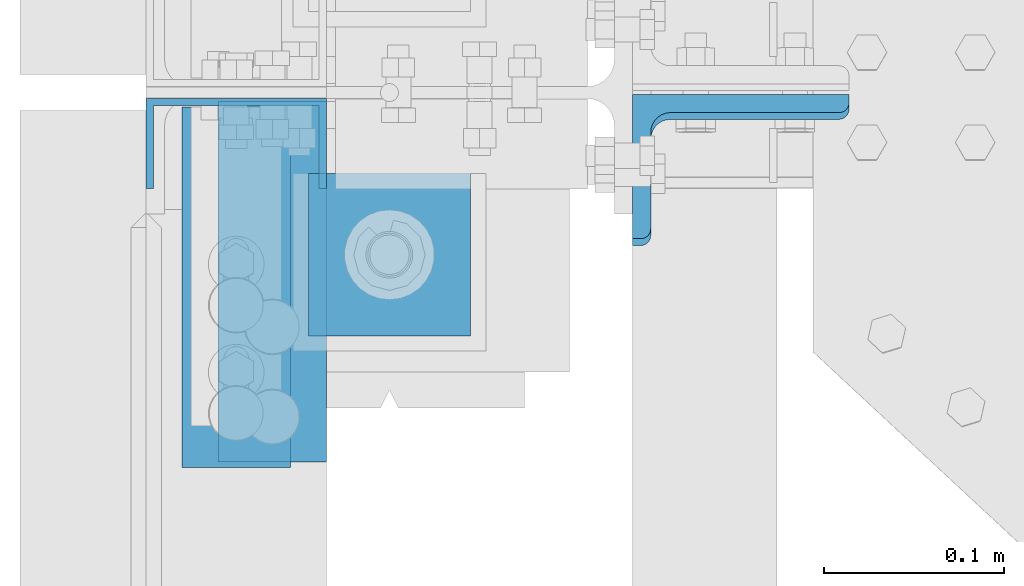
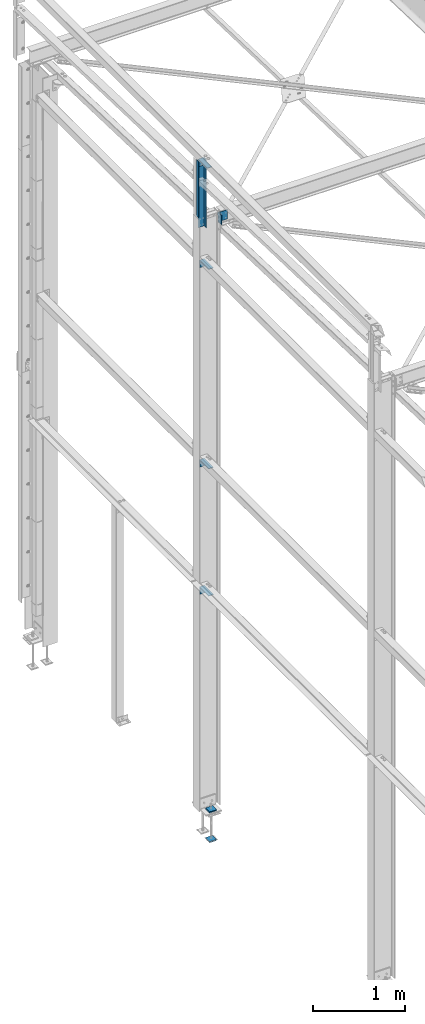
# One storey, part 74 of 496: 7 beams, 1 member, 7 elements without a shape of their own.
"""IFC2X3 building model written with IfcOpenShell, lengths in millimetres."""

from ifc_helpers import new_model, si_unit, frame, origin_with_axes, origin_2d_with_axis, place, context, subcontext, project, spatial, polyline, l_section, u_section, outline, extrude, boolean, material, type_object, element, aggregate, save


model = new_model("IFC2X3")

# Units and contexts
model_context = context("Model", 3, precision=1e-05, world=origin_with_axes())
body_context = subcontext(model_context, "Body", "Model", "MODEL_VIEW")
ifc_project = project(units=[si_unit("LENGTHUNIT", "METRE", prefix="MILLI"), si_unit("AREAUNIT", "SQUARE_METRE"), si_unit("VOLUMEUNIT", "CUBIC_METRE"), si_unit("MASSUNIT", "GRAM", prefix="KILO"), si_unit("TIMEUNIT", "SECOND"), si_unit("PLANEANGLEUNIT", "RADIAN"), si_unit("SOLIDANGLEUNIT", "STERADIAN"), si_unit("THERMODYNAMICTEMPERATUREUNIT", "DEGREE_CELSIUS"), si_unit("LUMINOUSINTENSITYUNIT", "LUMEN")], contexts=[model_context])

# Site, building, storey
site_placement = place(None, origin_with_axes())
site = spatial("IfcSite", under=ifc_project, at=site_placement, CompositionType="ELEMENT")
building_placement = place(site_placement, origin_with_axes())
building = spatial("IfcBuilding", under=site, at=building_placement, Name="Undefined", CompositionType="ELEMENT")
storey_placement = place(building_placement, origin_with_axes())
storey = spatial("IfcBuildingStorey", under=building, at=storey_placement, Name="Undefined", CompositionType="ELEMENT", Elevation=0.0)

# Assembly, beam
assembly_1_placement = place(storey_placement, origin_with_axes())
assembly_1 = element("IfcElementAssembly", 1, at=assembly_1_placement, inside=storey, AssemblyPlace="NOTDEFINED", PredefinedType="NOTDEFINED")
ifc_material = material(Name="Undefined/S235-E24")
beam_type_1 = type_object("IfcBeamType", PredefinedType="NOTDEFINED")
beam_1_placement = place(assembly_1_placement, frame((-130.000001390421, 11371.7000000475, 8445.0), z_axis=(1.0, 0.0, 0.0), x_axis=(0.0, 0.0, -1.0)))
beam_1 = element("IfcBeam", 2, at=beam_1_placement, type_object=beam_type_1, material=ifc_material, context=body_context, shape_type="CSG", body=[
    boolean("DIFFERENCE", extrude(u_section(Depth=100.0, FlangeWidth=50.0, WebThickness=4.0, FlangeThickness=4.0, at=origin_2d_with_axis()), frame((909.998684463201, 0.0, 0.0), z_axis=(-1.0, 0.0, 0.0), x_axis=(0.0, -1.0, 0.0)), (0.0, 0.0, 1.0), 910.0), extrude(outline(polyline([(0.0, 0.0), (20.0, 0.0), (19.9999939326024, 170.0), (-6.06739681074941e-06, 170.0), (0.0, 0.0)])), frame((739.998684463201, -27.5, -50.0000000000008), z_axis=(0.0, 1.0, 0.0), x_axis=(0.0, 0.0, 1.0)), (0.0, 0.0, 1.0), 55.0)),
])
aggregate(assembly_1, [beam_1])

assembly_2_placement = place(storey_placement, origin_with_axes())
assembly_2 = element("IfcElementAssembly", 3, at=assembly_2_placement, inside=storey, AssemblyPlace="NOTDEFINED", PredefinedType="NOTDEFINED")
beam_type_2 = type_object("IfcBeamType", PredefinedType="NOTDEFINED")
beam_2_placement = place(assembly_2_placement, frame((-159.999999787302, 11292.0, 8400.0), z_axis=(0.0, -1.0, 0.0), x_axis=(1.0, 0.0, 0.0)))
beam_2 = element("IfcBeam", 4, at=beam_2_placement, type_object=beam_type_2, material=ifc_material, context=body_context, shape_type="SweptSolid", body=[
    extrude(l_section(Depth=200.0, Width=100.0, Thickness=10.0, FilletRadius=15.0, EdgeRadius=7.5, at=origin_2d_with_axis()), frame((60.0, 0.0, 0.0), z_axis=(-1.0, 0.0, 0.0), x_axis=(0.0, -1.0, 0.0)), (0.0, 0.0, 1.0), 60.0),
])
aggregate(assembly_2, [beam_2])

assembly_3_placement = place(storey_placement, origin_with_axes())
assembly_3 = element("IfcElementAssembly", 5, at=assembly_3_placement, inside=storey, AssemblyPlace="NOTDEFINED", PredefinedType="NOTDEFINED")
beam_3_placement = place(assembly_3_placement, frame((-140.000006178405, 11295.0000004548, 2709.9999839346), z_axis=(0.0, -1.0, 0.0), x_axis=(1.0, 0.0, 0.0)))
beam_3 = element("IfcBeam", 6, at=beam_3_placement, type_object=beam_type_2, material=ifc_material, context=body_context, shape_type="SweptSolid", body=[
    extrude(l_section(Depth=200.0, Width=100.0, Thickness=10.0, FilletRadius=15.0, EdgeRadius=7.5, at=origin_2d_with_axis()), frame((60.0, 0.0, 0.0), z_axis=(-1.0, 0.0, 0.0), x_axis=(0.0, -1.0, 0.0)), (0.0, 0.0, 1.0), 60.0),
])
aggregate(assembly_3, [beam_3])

assembly_4_placement = place(storey_placement, origin_with_axes())
assembly_4 = element("IfcElementAssembly", 7, at=assembly_4_placement, inside=storey, AssemblyPlace="NOTDEFINED", PredefinedType="NOTDEFINED")
beam_4_placement = place(assembly_4_placement, frame((-140.000006178405, 11295.0000004548, 4399.99998404937), z_axis=(0.0, -1.0, 0.0), x_axis=(1.0, 0.0, 0.0)))
beam_4 = element("IfcBeam", 8, at=beam_4_placement, type_object=beam_type_2, material=ifc_material, context=body_context, shape_type="SweptSolid", body=[
    extrude(l_section(Depth=200.0, Width=100.0, Thickness=10.0, FilletRadius=15.0, EdgeRadius=7.5, at=origin_2d_with_axis()), frame((60.0, 0.0, 0.0), z_axis=(-1.0, 0.0, 0.0), x_axis=(0.0, -1.0, 0.0)), (0.0, 0.0, 1.0), 60.0),
])
aggregate(assembly_4, [beam_4])

assembly_5_placement = place(storey_placement, origin_with_axes())
assembly_5 = element("IfcElementAssembly", 9, at=assembly_5_placement, inside=storey, AssemblyPlace="NOTDEFINED", PredefinedType="NOTDEFINED")
beam_5_placement = place(assembly_5_placement, frame((-140.000006178405, 11295.0000004548, 7050.0), z_axis=(0.0, -1.0, 0.0), x_axis=(1.0, 0.0, 0.0)))
beam_5 = element("IfcBeam", 10, at=beam_5_placement, type_object=beam_type_2, material=ifc_material, context=body_context, shape_type="SweptSolid", body=[
    extrude(l_section(Depth=200.0, Width=100.0, Thickness=10.0, FilletRadius=15.0, EdgeRadius=7.5, at=origin_2d_with_axis()), frame((60.0, 0.0, 0.0), z_axis=(-1.0, 0.0, 0.0), x_axis=(0.0, -1.0, 0.0)), (0.0, 0.0, 1.0), 60.0),
])
aggregate(assembly_5, [beam_5])

# Assembly, member
assembly_6_placement = place(storey_placement, origin_with_axes())
assembly_6 = element("IfcElementAssembly", 11, at=assembly_6_placement, inside=storey, AssemblyPlace="NOTDEFINED", PredefinedType="NOTDEFINED")
member_type = type_object("IfcMemberType", PredefinedType="NOTDEFINED")
member_placement = place(assembly_6_placement, frame((149.99999999946, 11358.9063916518, 7653.00871666387), z_axis=(1.0, 0.0, 0.0), x_axis=(0.0, -0.031410887010906, -0.999506556345274)))
member = element("IfcMember", 12, at=member_placement, type_object=member_type, material=ifc_material, context=body_context, shape_type="SweptSolid", body=[
    extrude(l_section(Depth=120.0, Width=80.0, Thickness=10.0, FilletRadius=11.0, EdgeRadius=5.5, at=origin_2d_with_axis()), frame((120.0, 0.0, 0.0), z_axis=(-1.0, 0.0, 0.0), x_axis=(0.0, -1.0, 0.0)), (0.0, 0.0, 1.0), 120.0),
])
aggregate(assembly_6, [member])

# Assembly, beams
assembly_7_placement = place(storey_placement, origin_with_axes())
assembly_7 = element("IfcElementAssembly", 13, at=assembly_7_placement, inside=storey, Name="PS24", AssemblyPlace="NOTDEFINED", PredefinedType="NOTDEFINED")
beam_type_3 = type_object("IfcBeamType", PredefinedType="NOTDEFINED")
beam_6_placement = place(assembly_7_placement, frame((0.0, 11354.9971504447, -177.5), z_axis=(0.0, 0.0, 1.0), x_axis=(-1.0, 0.0, 0.0)))
beam_6 = element("IfcBeam", 14, at=beam_6_placement, type_object=beam_type_3, material=ifc_material, context=body_context, shape_type="SweptSolid", body=[
    extrude(outline(polyline([(0.0, 0.0), (90.0, 0.0), (90.0, 90.0), (0.0, 90.0), (0.0, 0.0)])), frame((0.0, 0.0, -7.5), z_axis=(0.0, 0.0, 1.0), x_axis=(1.0, 0.0, 0.0)), (0.0, 0.0, 1.0), 15.0),
])
beam_7_placement = place(assembly_7_placement, frame((0.0, 11354.9971504447, -572.5), z_axis=(0.0, 0.0, 1.0), x_axis=(-1.0, 0.0, 0.0)))
beam_7 = element("IfcBeam", 15, at=beam_7_placement, type_object=beam_type_3, material=ifc_material, context=body_context, shape_type="SweptSolid", body=[
    extrude(outline(polyline([(0.0, 0.0), (90.0, 0.0), (90.0, 90.0), (0.0, 90.0), (0.0, 0.0)])), frame((0.0, 0.0, -7.5), z_axis=(0.0, 0.0, 1.0), x_axis=(1.0, 0.0, 0.0)), (0.0, 0.0, 1.0), 15.0),
])
aggregate(assembly_7, [beam_6, beam_7])

save(model, "model.ifc")
